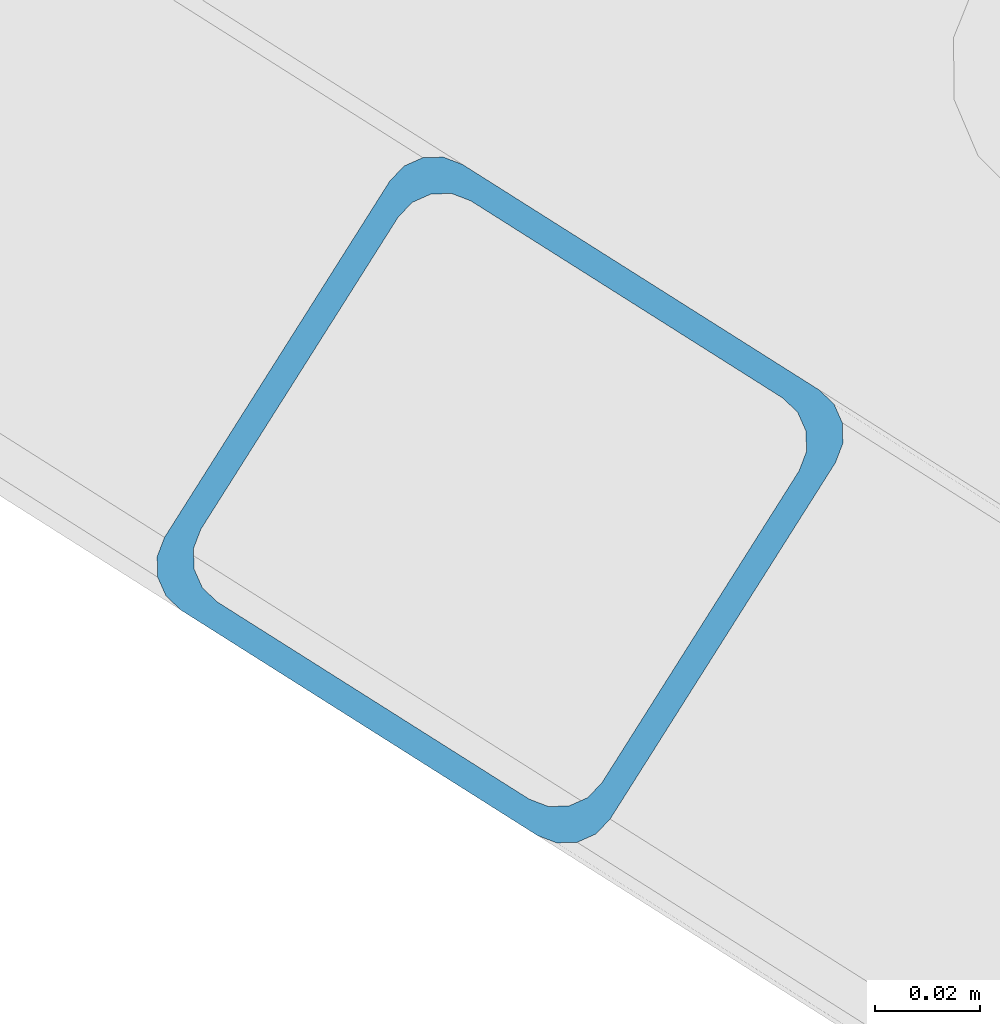
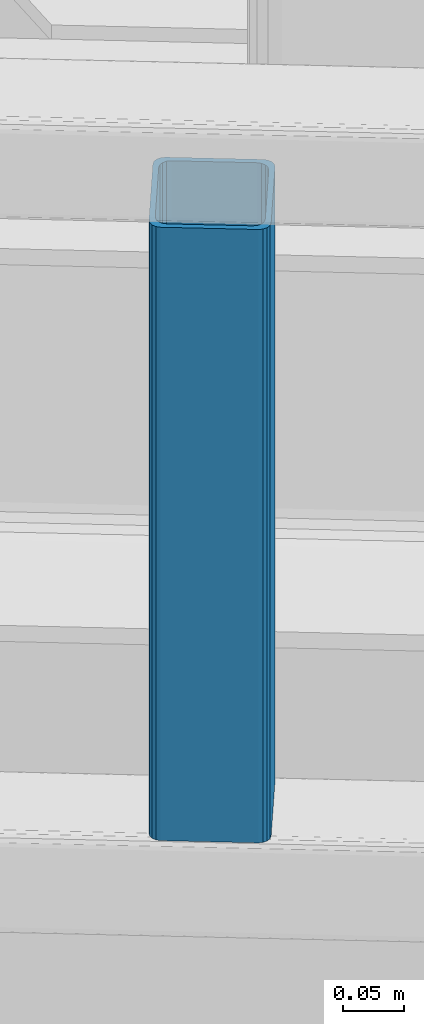
# One storey, part 12 of 93: 1 column.
"""IFC4 building model written with IfcOpenShell, lengths in millimetres."""

from ifc_helpers import new_model, entity, si_unit, converted_unit, derived_unit, direction, frame, origin, place, context, subcontext, project, spatial, indexed_curve, outline, extrude, type_object, element, save


model = new_model("IFC4")

# Units and contexts
model_context = context("Model", 3, precision=0.01, world=origin(), true_north=direction((6.12303176911189e-17, 1.0)))
plan_context = context("Plan", 3, precision=0.01, world=origin(), true_north=direction((6.12303176911189e-17, 1.0)))
body_context = subcontext(model_context, "Body", "Model", "MODEL_VIEW")
ifc_project = project(units=[si_unit("LENGTHUNIT", "METRE", prefix="MILLI"), si_unit("AREAUNIT", "SQUARE_METRE"), si_unit("VOLUMEUNIT", "CUBIC_METRE"), converted_unit("PLANEANGLEUNIT", "DEGREE", entity("IfcRatioMeasure", 0.0174532925199433), si_unit("PLANEANGLEUNIT", "RADIAN"), dimensions=[0, 0, 0, 0, 0, 0, 0]), si_unit("MASSUNIT", "GRAM", prefix="KILO"), derived_unit("MASSDENSITYUNIT", [(si_unit("MASSUNIT", "GRAM", prefix="KILO"), 1), (si_unit("LENGTHUNIT", "METRE"), -3)]), derived_unit("MOMENTOFINERTIAUNIT", [(si_unit("LENGTHUNIT", "METRE"), 4)]), si_unit("TIMEUNIT", "SECOND"), si_unit("FREQUENCYUNIT", "HERTZ"), si_unit("THERMODYNAMICTEMPERATUREUNIT", "DEGREE_CELSIUS"), derived_unit("THERMALTRANSMITTANCEUNIT", [(si_unit("MASSUNIT", "GRAM", prefix="KILO"), 1), (si_unit("THERMODYNAMICTEMPERATUREUNIT", "KELVIN"), -1), (si_unit("TIMEUNIT", "SECOND"), -3)]), derived_unit("VOLUMETRICFLOWRATEUNIT", [(si_unit("LENGTHUNIT", "METRE"), 3), (si_unit("TIMEUNIT", "SECOND"), -1)]), derived_unit("MASSFLOWRATEUNIT", [(si_unit("MASSUNIT", "GRAM", prefix="KILO"), 1), (si_unit("TIMEUNIT", "SECOND"), -1)]), derived_unit("ROTATIONALFREQUENCYUNIT", [(si_unit("TIMEUNIT", "SECOND"), -1)]), si_unit("ELECTRICCURRENTUNIT", "AMPERE"), si_unit("ELECTRICVOLTAGEUNIT", "VOLT"), si_unit("POWERUNIT", "WATT"), si_unit("FORCEUNIT", "NEWTON", prefix="KILO"), si_unit("ILLUMINANCEUNIT", "LUX"), si_unit("LUMINOUSFLUXUNIT", "LUMEN"), si_unit("LUMINOUSINTENSITYUNIT", "CANDELA"), derived_unit("USERDEFINED", [(si_unit("MASSUNIT", "GRAM", prefix="KILO"), -1), (si_unit("LENGTHUNIT", "METRE"), -2), (si_unit("TIMEUNIT", "SECOND"), 3), (si_unit("LUMINOUSFLUXUNIT", "LUMEN"), 1)]), derived_unit("LINEARVELOCITYUNIT", [(si_unit("LENGTHUNIT", "METRE"), 1), (si_unit("TIMEUNIT", "SECOND"), -1)]), si_unit("PRESSUREUNIT", "PASCAL"), derived_unit("USERDEFINED", [(si_unit("LENGTHUNIT", "METRE"), -2), (si_unit("MASSUNIT", "GRAM", prefix="KILO"), 1), (si_unit("TIMEUNIT", "SECOND"), -2)]), derived_unit("LINEARFORCEUNIT", [(si_unit("MASSUNIT", "GRAM", prefix="KILO"), 1), (si_unit("LENGTHUNIT", "METRE"), 1), (si_unit("TIMEUNIT", "SECOND"), -2), (si_unit("LENGTHUNIT", "METRE"), -1)]), derived_unit("PLANARFORCEUNIT", [(si_unit("MASSUNIT", "GRAM", prefix="KILO"), 1), (si_unit("LENGTHUNIT", "METRE"), 1), (si_unit("TIMEUNIT", "SECOND"), -2), (si_unit("LENGTHUNIT", "METRE"), -2)])], contexts=[model_context, plan_context])

# Site, building, storey
site_placement = place(None, origin())
site = spatial("IfcSite", under=ifc_project, at=site_placement, CompositionType="ELEMENT")
building_placement = place(site_placement, origin())
building = spatial("IfcBuilding", under=site, at=building_placement, CompositionType="ELEMENT")
storey_placement = place(building_placement, frame((0.0, 0.0, 15900.0)))
storey = spatial("IfcBuildingStorey", under=building, at=storey_placement, CompositionType="ELEMENT", Elevation=15900.0)

# Column
column_type = type_object("IfcColumnType", PredefinedType="COLUMN")
column_placement = place(storey_placement, origin())
element("IfcColumn", 1, at=column_placement, inside=storey, type_object=column_type, ObjectType="Steel Column", PredefinedType="COLUMN", context=body_context, shape_type="SweptSolid", body=[
    extrude(outline(indexed_curve([(29.476895115338, -56.8428769007487), (33.3787015556669, -56.8428769007487), (36.983500665699, -55.3497202197336), (39.7424944585263, -52.5907264268981), (41.2356511395292, -48.9859273168578), (56.8428769008052, 29.4768951153998), (56.8428769008048, 33.3787015557219), (55.3497202198055, 36.9835006657402), (52.5907264269724, 39.74249445857), (48.9859273169345, 41.235651139574), (-29.4768951153382, 56.8428769007431), (-33.37870155566, 56.8428769007367), (-36.9835006657023, 55.349720219736), (-39.7424944585296, 52.5907264269006), (-41.2356511395375, 48.9859273168674), (-56.8428769008154, -29.4768951153913), (-56.8428769008082, -33.3787015557193), (-55.3497202198007, -36.9835006657526), (-52.5907264269706, -39.7424944585747), (-48.9859273169378, -41.2356511395715), (29.476895115338, -56.8428769007487)], self_intersect=False), holes=[indexed_curve([(-43.1065493048402, -37.3071763476223), (-46.7113484148819, -35.8140196666204), (-49.4703422077054, -33.0550258738095), (-50.9634988887191, -29.450226763778), (-50.9634988887132, -25.548420323448), (-37.3071763476002, 43.1065493047872), (-35.8140196665925, 46.711348414815), (-33.0550258737631, 49.4703422076511), (-29.4502267637347, 50.9634988886636), (-25.5484203234035, 50.9634988886758), (43.106549304837, 37.3071763476427), (46.7113484148668, 35.8140196666416), (49.4703422077049, 33.0550258737987), (50.9634988887123, 29.4502267637654), (50.9634988887072, 25.5484203234516), (37.3071763475942, -43.1065493047656), (35.8140196665845, -46.7113484148004), (33.0550258737589, -49.47034220764), (29.4502267637176, -50.9634988886433), (25.5484203234017, -50.963498888647), (-43.1065493048402, -37.3071763476223)], self_intersect=False)]), frame((-309.933134904578, 12796.881132278, 3168.00446710615), z_axis=(0.0, 0.0, 1.0), x_axis=(-0.35919409370256, -0.933262879926763, 0.0)), (0.0, 0.0, 1.0), 611.999999999935),
])

save(model, "model.ifc")
